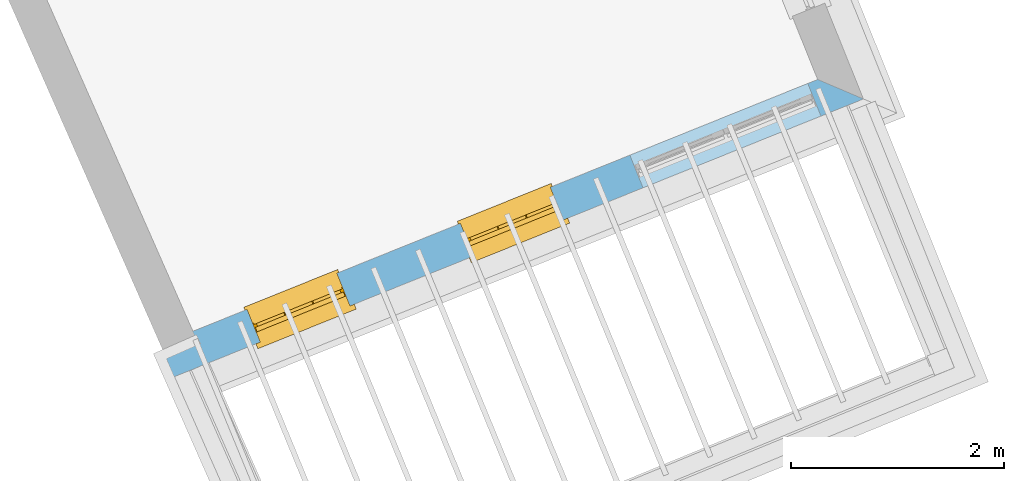
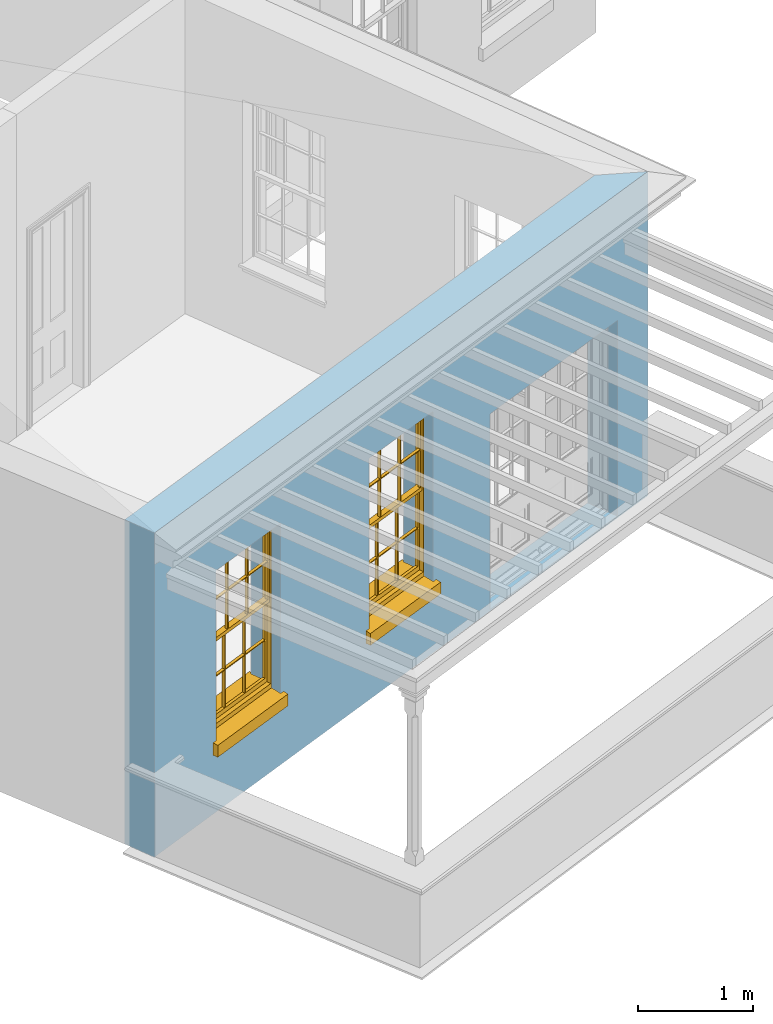
# One storey, part 2 of 11: 2 windows, 3 openings, plus 1 element that does not belong to this part.
"""IFC2X3 building model written with IfcOpenShell, lengths in metres."""

from ifc_helpers import new_model, si_unit, frame, origin, place, context, subcontext, project, spatial, polyline, outline, extrude, faceted_brep, material, layer, layer_set, layer_usage, element, fill, save


model = new_model("IFC2X3")

# Units and contexts
model_context = context("Model", 3, world=origin())
body_context = subcontext(model_context, "Body", "Model", "MODEL_VIEW")
ifc_project = project(units=[si_unit("PLANEANGLEUNIT", "RADIAN"), si_unit("MASSUNIT", "GRAM", prefix="KILO"), si_unit("FORCEUNIT", "NEWTON", prefix="KILO"), si_unit("LENGTHUNIT", "METRE")], contexts=[model_context])

# Site, building, storey
site_placement = place(None, origin())
site = spatial("IfcSite", under=ifc_project, at=site_placement, CompositionType="ELEMENT")
building_placement = place(None, origin())
building = spatial("IfcBuilding", under=site, at=building_placement, Name="Building plot-6", CompositionType="ELEMENT")
storey_placement = place(None, frame((0.0, 0.0, 7.6)))
storey = spatial("IfcBuildingStorey", under=building, at=storey_placement, Name="Floor 1", CompositionType="ELEMENT", Elevation=7.6)

# Wall, openings, windows
ifc_material = material(Name="Masonry")
ifc_layer = layer(ifc_material, 0.33, ventilated=False)
ifc_layer_set = layer_set([ifc_layer], Name="My Wall")
ifc_layer_usage = layer_usage(ifc_layer_set, "AXIS2", "NEGATIVE", 0.08)
wall_placement = place(storey_placement, origin())
wall = element("IfcWallStandardCase", 1, at=wall_placement, inside=storey, material=ifc_layer_usage, Name="exterior", context=body_context, shape_type="SweptSolid", body=[
    extrude(outline(polyline([(66.9666616124471, 55.8621028205896), (67.0900185225178, 55.5560259140157), (73.5616097026835, 58.1642445482227), (73.1321758860389, 58.3469645447258), (66.9666616124471, 55.8621028205896)])), origin(), (0.0, 0.0, 1.0), 3.45),
])
opening_1_placement = place(storey_placement, frame((0.0, 0.0, 0.75)))
opening_1 = element("IfcOpeningElement", 2, at=opening_1_placement, cuts=wall, Name="Opening", ObjectType="Opening", context=body_context, shape_type="SweptSolid", body=[
    extrude(outline(polyline([(67.9007863622407, 55.8827863240463), (68.7448166197625, 56.2229523487868), (68.6214597096917, 56.5290292553606), (67.77742945217, 56.1888632306201), (67.9007863622407, 55.8827863240463)])), origin(), (0.0, 0.0, 1.0), 1.82),
])
opening_2_placement = place(storey_placement, frame((0.0, 0.0, 0.75)))
opening_2 = element("IfcOpeningElement", 3, at=opening_2_placement, cuts=wall, Name="Opening", ObjectType="Opening", context=body_context, shape_type="SweptSolid", body=[
    extrude(outline(polyline([(69.9033991260465, 56.6898910657159), (70.7474293835683, 57.0300570904565), (70.6240724734975, 57.3361339970303), (69.7800422159758, 56.9959679722898), (69.9033991260465, 56.6898910657159)])), origin(), (0.0, 0.0, 1.0), 1.82),
])
opening_3_placement = place(storey_placement, frame((0.0, 0.0, 0.0199999999999996)))
element("IfcOpeningElement", 4, at=opening_3_placement, cuts=wall, Name="Opening", ObjectType="Opening", context=body_context, shape_type="SweptSolid", body=[
    extrude(outline(polyline([(71.4932718188664, 57.3306508831993), (73.16278221836, 58.0035067563124), (73.0394253082893, 58.3095836628862), (71.3699149087957, 57.6367277897731), (71.4932718188664, 57.3306508831993)])), origin(), (0.0, 0.0, 1.0), 2.08),
])
window_1_placement = place(storey_placement, frame((67.8073341576417, 56.1146627684204, 0.75), z_axis=(0.0, 0.0, 1.0), x_axis=(0.844030257521752, 0.340166024740519, 0.0)))
window_1 = element("IfcWindow", 5, at=window_1_placement, inside=storey, Name="living outside window", OverallHeight=1.82, OverallWidth=0.91, context=body_context, shape_type="Brep", held_by="IfcProductRepresentation", body=[
    faceted_brep([(0.033125, -0.105, 0.975209), (0.01, -0.105, 0.975209), (0.033125, -0.105, 1.376042), (0.876875, -0.105, 0.975209), (0.876875, -0.105, 1.376042), (0.9, -0.105, 0.975209), (0.876875, -0.105, 1.386042), (0.876875, -0.105, 1.786875), (0.9, -0.105, 1.81), (0.033125, -0.105, 1.786875), (0.033125, -0.105, 1.386042), (0.01, -0.105, 1.81), (0.876875, -0.135, 1.376042), (0.876875, -0.135, 0.975209), (0.9, -0.135, 0.937083), (0.033125, -0.135, 1.786875), (0.01, -0.135, 1.81), (0.033125, -0.135, 1.386042), (0.01, -0.135, 0.937083), (0.033125, -0.135, 0.975209), (0.033125, -0.135, 1.376042), (0.876875, -0.135, 1.786875), (0.876875, -0.135, 1.386042), (0.9, -0.135, 1.81), (0.033125, -0.105, 0.937083), (0.01, -0.105, 0.937083), (0.033125, -0.105, 0.53625), (0.876875, -0.105, 0.937083), (0.876875, -0.105, 0.53625), (0.9, -0.105, 0.937083), (0.876875, -0.105, 0.52625), (0.876875, -0.105, 0.125417), (0.9, -0.105, 0.077167), (0.033125, -0.105, 0.125417), (0.033125, -0.105, 0.52625), (0.01, -0.105, 0.077167), (-0.0425, -0.25, 0.01), (-0.0425, -0.3, 0.001667), (0.0, -0.25, 0.01), (0.9525, -0.25, 0.01), (0.91, -0.25, 0.01), (0.9525, -0.3, 0.001667), (-0.02, 0.08, 0.077167), (0.0, 0.08, 0.077167), (-0.02, 0.11, 0.077167), (0.0, -0.06, 0.077167), (0.01, -0.06, 0.077167), (0.91, -0.06, 0.077167), (0.91, 0.08, 0.077167), (0.9, -0.06, 0.077167), (0.93, 0.08, 0.077167), (0.93, 0.11, 0.077167), (0.01, -0.075, 0.975209), (0.9, -0.075, 0.975209), (0.876875, -0.075, 0.125417), (0.876875, -0.075, 0.52625), (0.9, -0.075, 0.077167), (0.876875, -0.075, 0.53625), (0.876875, -0.075, 0.937083), (0.033125, -0.075, 0.125417), (0.01, -0.075, 0.077167), (0.033125, -0.075, 0.52625), (0.033125, -0.075, 0.937083), (0.033125, -0.075, 0.53625), (-0.02, 0.08, 0.052167), (-0.02, 0.11, 0.052167), (0.93, 0.11, 0.052167), (0.93, 0.08, 0.052167), (0.91, 0.08, 0.052167), (0.0, 0.08, 0.052167), (0.91, -0.15, 0.026667), (0.0, -0.15, 0.026667), (-0.0425, -0.3, -0.123333), (0.9525, -0.3, -0.123333), (-0.0425, -0.25, -0.123333), (0.9525, -0.25, -0.123333), (0.01, -0.06, 1.81), (0.9, -0.06, 1.81), (0.0, -0.06, 1.82), (0.91, -0.06, 1.82), (0.01, -0.15, 0.077167), (0.9, -0.15, 0.077167), (0.592292, -0.105, 0.125417), (0.592292, -0.075, 0.125417), (0.317708, -0.075, 0.125417), (0.317708, -0.105, 0.125417), (0.592292, -0.105, 0.53625), (0.317708, -0.105, 0.53625), (0.317708, -0.105, 0.52625), (0.592292, -0.105, 0.52625), (0.592292, -0.075, 0.53625), (0.317708, -0.075, 0.53625), (0.592292, -0.135, 1.386042), (0.592292, -0.105, 1.386042), (0.317708, -0.105, 1.386042), (0.317708, -0.135, 1.386042), (0.317708, -0.135, 1.376042), (0.592292, -0.135, 1.376042), (0.317708, -0.105, 1.376042), (0.592292, -0.105, 1.376042), (0.602292, -0.135, 1.376042), (0.592292, -0.135, 0.975209), (0.602292, -0.135, 0.975209), (0.602292, -0.105, 0.975209), (0.592292, -0.105, 0.975209), (0.602292, -0.105, 1.376042), (0.602292, -0.075, 0.53625), (0.602292, -0.105, 0.53625), (0.317708, -0.075, 0.52625), (0.307708, -0.075, 0.125417), (0.307708, -0.075, 0.52625), (0.602292, -0.075, 0.52625), (0.602292, -0.075, 0.125417), (0.592292, -0.075, 0.52625), (0.307708, -0.075, 0.53625), (0.317708, -0.075, 0.937083), (0.307708, -0.075, 0.937083), (0.602292, -0.075, 0.937083), (0.592292, -0.075, 0.937083), (0.307708, -0.105, 0.52625), (0.307708, -0.105, 0.125417), (0.307708, -0.105, 0.53625), (0.307708, -0.105, 0.937083), (0.592292, -0.105, 0.937083), (0.317708, -0.105, 0.937083), (0.602292, -0.105, 0.937083), (0.602292, -0.105, 0.52625), (0.602292, -0.105, 0.125417), (0.307708, -0.135, 1.386042), (0.307708, -0.135, 1.376042), (0.307708, -0.135, 0.975209), (0.317708, -0.135, 0.975209), (0.317708, -0.135, 1.786875), (0.307708, -0.135, 1.786875), (0.602292, -0.135, 1.786875), (0.592292, -0.135, 1.786875), (0.602292, -0.135, 1.386042), (0.602292, -0.105, 1.386042), (0.307708, -0.105, 1.386042), (0.307708, -0.105, 1.786875), (0.317708, -0.105, 1.786875), (0.592292, -0.105, 1.786875), (0.602292, -0.105, 1.786875), (0.307708, -0.105, 1.376042), (0.317708, -0.105, 0.975209), (0.307708, -0.105, 0.975209), (0.91, -0.15, 1.82), (0.9, -0.15, 1.81), (0.01, -0.15, 1.81), (0.0, -0.15, 1.82), (0.91, -0.25, 0.0), (0.0, -0.25, 0.0), (0.91, 0.08, 0.0), (0.0, 0.08, 0.0)], [[[0, 1, 2]], [[3, 4, 5]], [[6, 7, 8]], [[9, 10, 11]], [[12, 13, 14]], [[15, 16, 17]], [[18, 19, 20]], [[21, 22, 23]], [[24, 25, 26]], [[27, 28, 29]], [[30, 31, 32]], [[33, 34, 35]], [[14, 27, 29]], [[25, 24, 18]], [[36, 37, 38]], [[39, 40, 41]], [[42, 43, 44]], [[45, 46, 43]], [[47, 48, 49]], [[50, 51, 48]], [[1, 0, 52]], [[5, 53, 3]], [[54, 55, 56]], [[57, 58, 53]], [[59, 60, 61]], [[62, 63, 52]], [[48, 43, 46, 49]], [[51, 44, 43, 48]], [[64, 42, 44, 65]], [[65, 44, 51, 66]], [[66, 51, 50, 67]], [[65, 66, 68, 69]], [[60, 56, 49, 46]], [[70, 71, 38, 40]], [[37, 41, 40, 38]], [[37, 72, 73, 41]], [[74, 75, 73, 72]], [[8, 11, 76, 77]], [[76, 78, 79, 77]], [[32, 35, 80, 81]], [[81, 80, 71, 70]], [[82, 83, 84, 85]], [[86, 87, 88, 89]], [[86, 90, 91, 87]], [[92, 93, 94, 95]], [[92, 95, 96, 97]], [[96, 98, 99, 97]], [[100, 97, 101, 102]], [[103, 104, 99, 105]], [[97, 99, 104, 101]], [[102, 103, 105, 100]], [[28, 57, 106, 107]], [[108, 84, 109, 110]], [[111, 112, 83, 113]], [[114, 110, 61, 63]], [[90, 113, 108, 91]], [[115, 91, 114, 116]], [[117, 106, 90, 118]], [[111, 106, 57, 55]], [[119, 110, 109, 120]], [[34, 61, 110, 119]], [[89, 113, 83, 82]], [[88, 108, 113, 89]], [[85, 84, 108, 88]], [[121, 114, 63, 26]], [[122, 116, 114, 121]], [[123, 118, 90, 86]], [[87, 91, 115, 124]], [[107, 106, 117, 125]], [[126, 111, 55, 30]], [[127, 112, 111, 126]], [[126, 30, 28, 107]], [[88, 119, 120, 85]], [[126, 89, 82, 127]], [[125, 123, 86, 107]], [[121, 26, 34, 119]], [[124, 122, 121, 87]], [[128, 17, 20, 129]], [[96, 129, 130, 131]], [[132, 133, 128, 95]], [[134, 135, 92, 136]], [[100, 12, 22, 136]], [[137, 6, 4, 105]], [[94, 138, 139, 140]], [[137, 93, 141, 142]], [[99, 98, 94, 93]], [[143, 2, 10, 138]], [[144, 145, 143, 98]], [[129, 143, 145, 130]], [[20, 2, 143, 129]], [[131, 144, 98, 96]], [[128, 138, 10, 17]], [[133, 139, 138, 128]], [[135, 141, 93, 92]], [[95, 94, 140, 132]], [[22, 6, 137, 136]], [[136, 137, 142, 134]], [[100, 105, 4, 12]], [[107, 86, 89, 126]], [[106, 111, 113, 90]], [[91, 108, 110, 114]], [[87, 121, 119, 88]], [[97, 100, 136, 92]], [[129, 96, 95, 128]], [[98, 143, 138, 94]], [[105, 99, 93, 137]], [[131, 101, 104, 144]], [[124, 115, 118, 123]], [[132, 140, 141, 135]], [[120, 109, 59, 33]], [[15, 9, 139, 133]], [[134, 142, 7, 21]], [[31, 54, 112, 127]], [[36, 74, 72, 37]], [[39, 41, 73, 75]], [[18, 14, 101, 131]], [[23, 16, 132, 135]], [[83, 56, 60, 84]], [[52, 53, 118, 115]], [[53, 52, 144, 104]], [[11, 8, 141, 140]], [[14, 18, 124, 123]], [[2, 1, 11, 10]], [[8, 5, 4, 6]], [[57, 53, 56, 55]], [[60, 52, 63, 61]], [[26, 25, 35, 34]], [[32, 29, 28, 30]], [[14, 23, 22, 12]], [[18, 20, 17, 16]], [[19, 0, 2, 20]], [[17, 10, 9, 15]], [[12, 4, 3, 13]], [[21, 7, 6, 22]], [[27, 58, 57, 28]], [[30, 55, 54, 31]], [[33, 59, 61, 34]], [[26, 63, 62, 24]], [[5, 8, 77, 53]], [[76, 11, 1, 52]], [[46, 45, 78, 76]], [[49, 77, 79, 47]], [[70, 146, 147, 81]], [[71, 80, 148, 149]], [[19, 130, 145, 0]], [[102, 13, 3, 103]], [[116, 122, 24, 62]], [[29, 32, 81, 14]], [[80, 35, 25, 18]], [[60, 46, 76, 52]], [[77, 49, 56, 53]], [[23, 14, 81, 147]], [[16, 148, 80, 18]], [[35, 85, 120]], [[120, 33, 35]], [[127, 82, 32]], [[32, 31, 127]], [[32, 82, 85, 35]], [[102, 101, 14]], [[14, 13, 102]], [[18, 131, 130]], [[130, 19, 18]], [[134, 21, 23]], [[23, 135, 134]], [[16, 15, 133]], [[133, 132, 16]], [[11, 140, 139]], [[139, 9, 11]], [[142, 141, 8]], [[8, 7, 142]], [[23, 147, 148, 16]], [[146, 149, 148, 147]], [[52, 115, 116]], [[116, 62, 52]], [[118, 53, 117]], [[58, 117, 53]], [[27, 125, 117, 58]], [[56, 83, 112]], [[112, 54, 56]], [[109, 84, 60]], [[60, 59, 109]], [[125, 27, 14]], [[14, 123, 125]], [[122, 124, 18]], [[18, 24, 122]], [[145, 144, 52]], [[52, 0, 145]], [[103, 3, 53]], [[53, 104, 103]], [[79, 78, 149, 146]], [[78, 45, 71, 149]], [[146, 70, 47, 79]], [[150, 75, 74, 151]], [[68, 66, 67]], [[48, 68, 67, 50]], [[69, 64, 65]], [[42, 64, 69, 43]], [[69, 68, 152, 153]], [[70, 68, 48, 47]], [[150, 152, 68, 70]], [[43, 69, 71, 45]], [[69, 153, 151, 71]], [[152, 150, 151, 153]], [[38, 151, 74, 36]], [[71, 151, 38]], [[39, 75, 150, 40]], [[40, 150, 70]]]),
])
fill(opening_1, window_1)
window_2_placement = place(storey_placement, frame((69.8099469214475, 56.92176751009, 0.75), z_axis=(0.0, 0.0, 1.0), x_axis=(0.844030257521752, 0.340166024740519, 0.0)))
window_2 = element("IfcWindow", 6, at=window_2_placement, inside=storey, Name="living outside window", OverallHeight=1.82, OverallWidth=0.91, context=body_context, shape_type="Brep", held_by="IfcProductRepresentation", body=[
    faceted_brep([(0.033125, -0.105, 0.975209), (0.01, -0.105, 0.975209), (0.033125, -0.105, 1.376042), (0.876875, -0.105, 0.975209), (0.876875, -0.105, 1.376042), (0.9, -0.105, 0.975209), (0.876875, -0.105, 1.386042), (0.876875, -0.105, 1.786875), (0.9, -0.105, 1.81), (0.033125, -0.105, 1.786875), (0.033125, -0.105, 1.386042), (0.01, -0.105, 1.81), (0.876875, -0.135, 1.376042), (0.876875, -0.135, 0.975209), (0.9, -0.135, 0.937083), (0.033125, -0.135, 1.786875), (0.01, -0.135, 1.81), (0.033125, -0.135, 1.386042), (0.01, -0.135, 0.937083), (0.033125, -0.135, 0.975209), (0.033125, -0.135, 1.376042), (0.876875, -0.135, 1.786875), (0.876875, -0.135, 1.386042), (0.9, -0.135, 1.81), (0.033125, -0.105, 0.937083), (0.01, -0.105, 0.937083), (0.033125, -0.105, 0.53625), (0.876875, -0.105, 0.937083), (0.876875, -0.105, 0.53625), (0.9, -0.105, 0.937083), (0.876875, -0.105, 0.52625), (0.876875, -0.105, 0.125417), (0.9, -0.105, 0.077167), (0.033125, -0.105, 0.125417), (0.033125, -0.105, 0.52625), (0.01, -0.105, 0.077167), (-0.0425, -0.25, 0.01), (-0.0425, -0.3, 0.001667), (0.0, -0.25, 0.01), (0.9525, -0.25, 0.01), (0.91, -0.25, 0.01), (0.9525, -0.3, 0.001667), (-0.02, 0.08, 0.077167), (0.0, 0.08, 0.077167), (-0.02, 0.11, 0.077167), (0.0, -0.06, 0.077167), (0.01, -0.06, 0.077167), (0.91, -0.06, 0.077167), (0.91, 0.08, 0.077167), (0.9, -0.06, 0.077167), (0.93, 0.08, 0.077167), (0.93, 0.11, 0.077167), (0.01, -0.075, 0.975209), (0.9, -0.075, 0.975209), (0.876875, -0.075, 0.125417), (0.876875, -0.075, 0.52625), (0.9, -0.075, 0.077167), (0.876875, -0.075, 0.53625), (0.876875, -0.075, 0.937083), (0.033125, -0.075, 0.125417), (0.01, -0.075, 0.077167), (0.033125, -0.075, 0.52625), (0.033125, -0.075, 0.937083), (0.033125, -0.075, 0.53625), (-0.02, 0.08, 0.052167), (-0.02, 0.11, 0.052167), (0.93, 0.11, 0.052167), (0.93, 0.08, 0.052167), (0.91, 0.08, 0.052167), (0.0, 0.08, 0.052167), (0.91, -0.15, 0.026667), (0.0, -0.15, 0.026667), (-0.0425, -0.3, -0.123333), (0.9525, -0.3, -0.123333), (-0.0425, -0.25, -0.123333), (0.9525, -0.25, -0.123333), (0.01, -0.06, 1.81), (0.9, -0.06, 1.81), (0.0, -0.06, 1.82), (0.91, -0.06, 1.82), (0.01, -0.15, 0.077167), (0.9, -0.15, 0.077167), (0.592292, -0.105, 0.125417), (0.592292, -0.075, 0.125417), (0.317708, -0.075, 0.125417), (0.317708, -0.105, 0.125417), (0.592292, -0.105, 0.53625), (0.317708, -0.105, 0.53625), (0.317708, -0.105, 0.52625), (0.592292, -0.105, 0.52625), (0.592292, -0.075, 0.53625), (0.317708, -0.075, 0.53625), (0.592292, -0.135, 1.386042), (0.592292, -0.105, 1.386042), (0.317708, -0.105, 1.386042), (0.317708, -0.135, 1.386042), (0.317708, -0.135, 1.376042), (0.592292, -0.135, 1.376042), (0.317708, -0.105, 1.376042), (0.592292, -0.105, 1.376042), (0.602292, -0.135, 1.376042), (0.592292, -0.135, 0.975209), (0.602292, -0.135, 0.975209), (0.602292, -0.105, 0.975209), (0.592292, -0.105, 0.975209), (0.602292, -0.105, 1.376042), (0.602292, -0.075, 0.53625), (0.602292, -0.105, 0.53625), (0.317708, -0.075, 0.52625), (0.307708, -0.075, 0.125417), (0.307708, -0.075, 0.52625), (0.602292, -0.075, 0.52625), (0.602292, -0.075, 0.125417), (0.592292, -0.075, 0.52625), (0.307708, -0.075, 0.53625), (0.317708, -0.075, 0.937083), (0.307708, -0.075, 0.937083), (0.602292, -0.075, 0.937083), (0.592292, -0.075, 0.937083), (0.307708, -0.105, 0.52625), (0.307708, -0.105, 0.125417), (0.307708, -0.105, 0.53625), (0.307708, -0.105, 0.937083), (0.592292, -0.105, 0.937083), (0.317708, -0.105, 0.937083), (0.602292, -0.105, 0.937083), (0.602292, -0.105, 0.52625), (0.602292, -0.105, 0.125417), (0.307708, -0.135, 1.386042), (0.307708, -0.135, 1.376042), (0.307708, -0.135, 0.975209), (0.317708, -0.135, 0.975209), (0.317708, -0.135, 1.786875), (0.307708, -0.135, 1.786875), (0.602292, -0.135, 1.786875), (0.592292, -0.135, 1.786875), (0.602292, -0.135, 1.386042), (0.602292, -0.105, 1.386042), (0.307708, -0.105, 1.386042), (0.307708, -0.105, 1.786875), (0.317708, -0.105, 1.786875), (0.592292, -0.105, 1.786875), (0.602292, -0.105, 1.786875), (0.307708, -0.105, 1.376042), (0.317708, -0.105, 0.975209), (0.307708, -0.105, 0.975209), (0.91, -0.15, 1.82), (0.9, -0.15, 1.81), (0.01, -0.15, 1.81), (0.0, -0.15, 1.82), (0.91, -0.25, 0.0), (0.0, -0.25, 0.0), (0.91, 0.08, 0.0), (0.0, 0.08, 0.0)], [[[0, 1, 2]], [[3, 4, 5]], [[6, 7, 8]], [[9, 10, 11]], [[12, 13, 14]], [[15, 16, 17]], [[18, 19, 20]], [[21, 22, 23]], [[24, 25, 26]], [[27, 28, 29]], [[30, 31, 32]], [[33, 34, 35]], [[14, 27, 29]], [[25, 24, 18]], [[36, 37, 38]], [[39, 40, 41]], [[42, 43, 44]], [[45, 46, 43]], [[47, 48, 49]], [[50, 51, 48]], [[1, 0, 52]], [[5, 53, 3]], [[54, 55, 56]], [[57, 58, 53]], [[59, 60, 61]], [[62, 63, 52]], [[48, 43, 46, 49]], [[51, 44, 43, 48]], [[64, 42, 44, 65]], [[65, 44, 51, 66]], [[66, 51, 50, 67]], [[65, 66, 68, 69]], [[60, 56, 49, 46]], [[70, 71, 38, 40]], [[37, 41, 40, 38]], [[37, 72, 73, 41]], [[74, 75, 73, 72]], [[8, 11, 76, 77]], [[76, 78, 79, 77]], [[32, 35, 80, 81]], [[81, 80, 71, 70]], [[82, 83, 84, 85]], [[86, 87, 88, 89]], [[86, 90, 91, 87]], [[92, 93, 94, 95]], [[92, 95, 96, 97]], [[96, 98, 99, 97]], [[100, 97, 101, 102]], [[103, 104, 99, 105]], [[97, 99, 104, 101]], [[102, 103, 105, 100]], [[28, 57, 106, 107]], [[108, 84, 109, 110]], [[111, 112, 83, 113]], [[114, 110, 61, 63]], [[90, 113, 108, 91]], [[115, 91, 114, 116]], [[117, 106, 90, 118]], [[111, 106, 57, 55]], [[119, 110, 109, 120]], [[34, 61, 110, 119]], [[89, 113, 83, 82]], [[88, 108, 113, 89]], [[85, 84, 108, 88]], [[121, 114, 63, 26]], [[122, 116, 114, 121]], [[123, 118, 90, 86]], [[87, 91, 115, 124]], [[107, 106, 117, 125]], [[126, 111, 55, 30]], [[127, 112, 111, 126]], [[126, 30, 28, 107]], [[88, 119, 120, 85]], [[126, 89, 82, 127]], [[125, 123, 86, 107]], [[121, 26, 34, 119]], [[124, 122, 121, 87]], [[128, 17, 20, 129]], [[96, 129, 130, 131]], [[132, 133, 128, 95]], [[134, 135, 92, 136]], [[100, 12, 22, 136]], [[137, 6, 4, 105]], [[94, 138, 139, 140]], [[137, 93, 141, 142]], [[99, 98, 94, 93]], [[143, 2, 10, 138]], [[144, 145, 143, 98]], [[129, 143, 145, 130]], [[20, 2, 143, 129]], [[131, 144, 98, 96]], [[128, 138, 10, 17]], [[133, 139, 138, 128]], [[135, 141, 93, 92]], [[95, 94, 140, 132]], [[22, 6, 137, 136]], [[136, 137, 142, 134]], [[100, 105, 4, 12]], [[107, 86, 89, 126]], [[106, 111, 113, 90]], [[91, 108, 110, 114]], [[87, 121, 119, 88]], [[97, 100, 136, 92]], [[129, 96, 95, 128]], [[98, 143, 138, 94]], [[105, 99, 93, 137]], [[131, 101, 104, 144]], [[124, 115, 118, 123]], [[132, 140, 141, 135]], [[120, 109, 59, 33]], [[15, 9, 139, 133]], [[134, 142, 7, 21]], [[31, 54, 112, 127]], [[36, 74, 72, 37]], [[39, 41, 73, 75]], [[18, 14, 101, 131]], [[23, 16, 132, 135]], [[83, 56, 60, 84]], [[52, 53, 118, 115]], [[53, 52, 144, 104]], [[11, 8, 141, 140]], [[14, 18, 124, 123]], [[2, 1, 11, 10]], [[8, 5, 4, 6]], [[57, 53, 56, 55]], [[60, 52, 63, 61]], [[26, 25, 35, 34]], [[32, 29, 28, 30]], [[14, 23, 22, 12]], [[18, 20, 17, 16]], [[19, 0, 2, 20]], [[17, 10, 9, 15]], [[12, 4, 3, 13]], [[21, 7, 6, 22]], [[27, 58, 57, 28]], [[30, 55, 54, 31]], [[33, 59, 61, 34]], [[26, 63, 62, 24]], [[5, 8, 77, 53]], [[76, 11, 1, 52]], [[46, 45, 78, 76]], [[49, 77, 79, 47]], [[70, 146, 147, 81]], [[71, 80, 148, 149]], [[19, 130, 145, 0]], [[102, 13, 3, 103]], [[116, 122, 24, 62]], [[29, 32, 81, 14]], [[80, 35, 25, 18]], [[60, 46, 76, 52]], [[77, 49, 56, 53]], [[23, 14, 81, 147]], [[16, 148, 80, 18]], [[35, 85, 120]], [[120, 33, 35]], [[127, 82, 32]], [[32, 31, 127]], [[32, 82, 85, 35]], [[102, 101, 14]], [[14, 13, 102]], [[18, 131, 130]], [[130, 19, 18]], [[134, 21, 23]], [[23, 135, 134]], [[16, 15, 133]], [[133, 132, 16]], [[11, 140, 139]], [[139, 9, 11]], [[142, 141, 8]], [[8, 7, 142]], [[23, 147, 148, 16]], [[146, 149, 148, 147]], [[52, 115, 116]], [[116, 62, 52]], [[118, 53, 117]], [[58, 117, 53]], [[27, 125, 117, 58]], [[56, 83, 112]], [[112, 54, 56]], [[109, 84, 60]], [[60, 59, 109]], [[125, 27, 14]], [[14, 123, 125]], [[122, 124, 18]], [[18, 24, 122]], [[145, 144, 52]], [[52, 0, 145]], [[103, 3, 53]], [[53, 104, 103]], [[79, 78, 149, 146]], [[78, 45, 71, 149]], [[146, 70, 47, 79]], [[150, 75, 74, 151]], [[68, 66, 67]], [[48, 68, 67, 50]], [[69, 64, 65]], [[42, 64, 69, 43]], [[69, 68, 152, 153]], [[70, 68, 48, 47]], [[150, 152, 68, 70]], [[43, 69, 71, 45]], [[69, 153, 151, 71]], [[152, 150, 151, 153]], [[38, 151, 74, 36]], [[71, 151, 38]], [[39, 75, 150, 40]], [[40, 150, 70]]]),
])
fill(opening_2, window_2)

save(model, "model.ifc")
